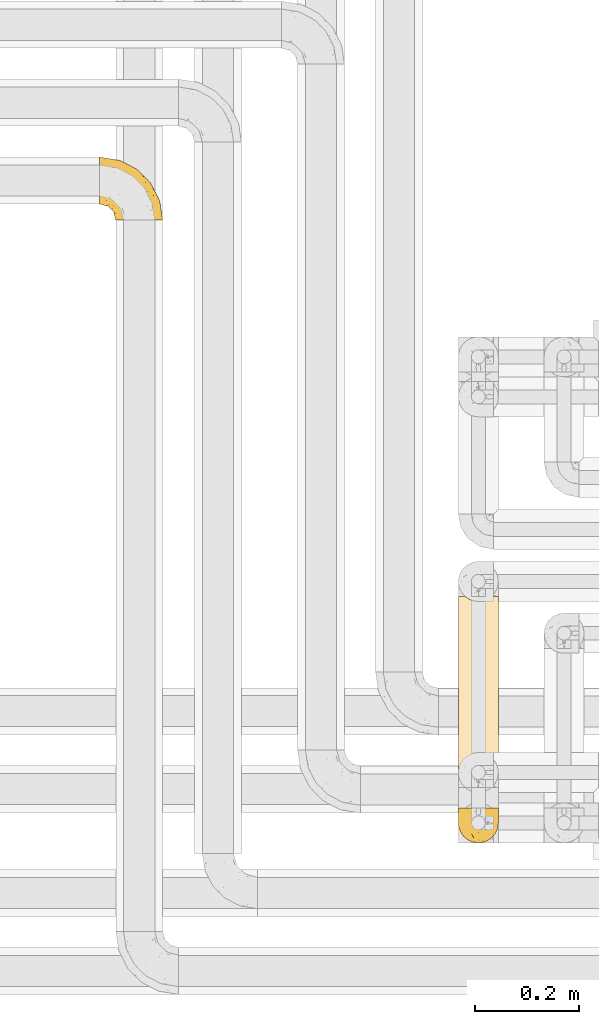
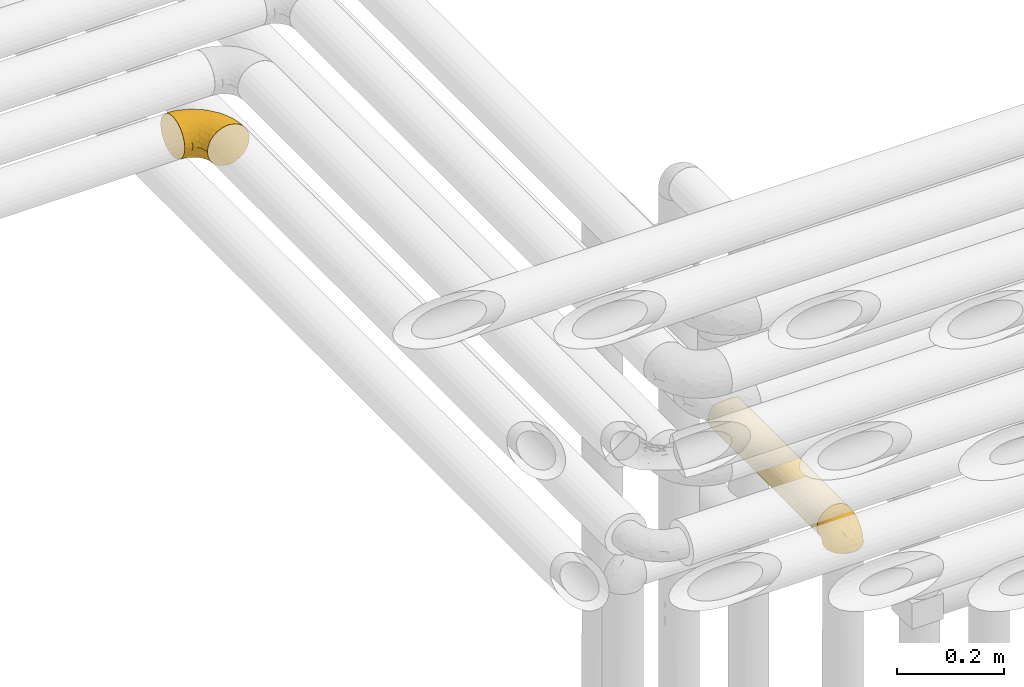
# One storey, part 285 of 827: 3 coverings.
"""IFC2X3 building model written with IfcOpenShell, lengths in millimetres."""

from ifc_helpers import new_model, entity, si_unit, converted_unit, derived_unit, direction, frame, origin, place, context, subcontext, project, spatial, faceted_brep, element, save


model = new_model("IFC2X3")

# Units and contexts
model_context = context("Model", 3, precision=0.01, world=origin(), true_north=direction((6.12303176911189e-17, 1.0)))
body_context = subcontext(model_context, "Body", "Model", "MODEL_VIEW")
ifc_project = project(units=[si_unit("LENGTHUNIT", "METRE", prefix="MILLI"), si_unit("AREAUNIT", "SQUARE_METRE"), si_unit("VOLUMEUNIT", "CUBIC_METRE"), converted_unit("PLANEANGLEUNIT", "DEGREE", entity("IfcRatioMeasure", 0.0174532925199433), si_unit("PLANEANGLEUNIT", "RADIAN"), dimensions=[0, 0, 0, 0, 0, 0, 0]), si_unit("MASSUNIT", "GRAM", prefix="KILO"), derived_unit("MASSDENSITYUNIT", [(si_unit("MASSUNIT", "GRAM", prefix="KILO"), 1), (si_unit("LENGTHUNIT", "METRE"), -3)]), derived_unit("MOMENTOFINERTIAUNIT", [(si_unit("LENGTHUNIT", "METRE"), 4)]), si_unit("TIMEUNIT", "SECOND"), si_unit("FREQUENCYUNIT", "HERTZ"), si_unit("THERMODYNAMICTEMPERATUREUNIT", "DEGREE_CELSIUS"), derived_unit("THERMALTRANSMITTANCEUNIT", [(si_unit("MASSUNIT", "GRAM", prefix="KILO"), 1), (si_unit("THERMODYNAMICTEMPERATUREUNIT", "KELVIN"), -1), (si_unit("TIMEUNIT", "SECOND"), -3)]), derived_unit("VOLUMETRICFLOWRATEUNIT", [(si_unit("LENGTHUNIT", "METRE"), 3), (si_unit("TIMEUNIT", "SECOND"), -1)]), derived_unit("MASSFLOWRATEUNIT", [(si_unit("MASSUNIT", "GRAM", prefix="KILO"), 1), (si_unit("TIMEUNIT", "SECOND"), -1)]), derived_unit("ROTATIONALFREQUENCYUNIT", [(si_unit("TIMEUNIT", "SECOND"), -1)]), si_unit("ELECTRICCURRENTUNIT", "AMPERE"), si_unit("ELECTRICVOLTAGEUNIT", "VOLT"), si_unit("POWERUNIT", "WATT"), si_unit("FORCEUNIT", "NEWTON", prefix="KILO"), si_unit("ILLUMINANCEUNIT", "LUX"), si_unit("LUMINOUSFLUXUNIT", "LUMEN"), si_unit("LUMINOUSINTENSITYUNIT", "CANDELA"), derived_unit("USERDEFINED", [(si_unit("MASSUNIT", "GRAM", prefix="KILO"), -1), (si_unit("LENGTHUNIT", "METRE"), -2), (si_unit("TIMEUNIT", "SECOND"), 3), (si_unit("LUMINOUSFLUXUNIT", "LUMEN"), 1)]), derived_unit("LINEARVELOCITYUNIT", [(si_unit("LENGTHUNIT", "METRE"), 1), (si_unit("TIMEUNIT", "SECOND"), -1)]), si_unit("PRESSUREUNIT", "PASCAL"), derived_unit("USERDEFINED", [(si_unit("LENGTHUNIT", "METRE"), -2), (si_unit("MASSUNIT", "GRAM", prefix="KILO"), 1), (si_unit("TIMEUNIT", "SECOND"), -2)]), derived_unit("LINEARFORCEUNIT", [(si_unit("MASSUNIT", "GRAM", prefix="KILO"), 1), (si_unit("LENGTHUNIT", "METRE"), 1), (si_unit("TIMEUNIT", "SECOND"), -2), (si_unit("LENGTHUNIT", "METRE"), -1)]), derived_unit("PLANARFORCEUNIT", [(si_unit("MASSUNIT", "GRAM", prefix="KILO"), 1), (si_unit("LENGTHUNIT", "METRE"), 1), (si_unit("TIMEUNIT", "SECOND"), -2), (si_unit("LENGTHUNIT", "METRE"), -2)])], contexts=[model_context])

# Site, building, storey
site_placement = place(None, origin())
site = spatial("IfcSite", under=ifc_project, at=site_placement, CompositionType="ELEMENT")
building_placement = place(site_placement, origin())
building = spatial("IfcBuilding", under=site, at=building_placement, CompositionType="ELEMENT")
storey_placement = place(building_placement, frame((0.0, 0.0, 28200.0)))
storey = spatial("IfcBuildingStorey", under=building, at=storey_placement, Name="08", CompositionType="ELEMENT", Elevation=28200.0)

# Coverings
covering_1_placement = place(storey_placement, frame((34097.44, 16083.61, 3153.25)))
element("IfcCovering", 1, at=covering_1_placement, inside=storey, Name=":ADSK_", ObjectType=":ADSK_", PredefinedType="INSULATION", context=body_context, shape_type="Brep", body=[
    faceted_brep([(1.6, 87.65, 90.76), (1.6, 97.19, 87.42), (1.6, 105.75, 82.04), (1.6, 112.9, 74.89), (1.6, 118.28, 66.33), (1.6, 121.61, 56.79), (1.6, 122.75, 46.75), (1.6, 121.61, 36.69), (1.6, 118.27, 27.15), (1.6, 112.89, 18.59), (1.6, 105.74, 11.44), (1.6, 97.18, 6.06), (1.6, 87.64, 2.73), (1.6, 77.6, 1.6), (1.6, 67.54, 2.73), (1.6, 58.0, 6.07), (1.6, 49.44, 11.45), (1.6, 42.29, 18.6), (1.6, 36.91, 27.16), (1.6, 33.58, 36.7), (1.6, 32.45, 46.75), (1.6, 33.58, 56.8), (1.6, 36.92, 66.34), (1.6, 42.3, 74.9), (1.6, 49.45, 82.05), (1.6, 58.01, 87.43), (1.6, 67.55, 90.76), (1.6, 77.6, 91.9), (33.98, 1.6, 35.06), (38.49, 1.6, 24.17), (45.67, 1.6, 14.82), (55.02, 1.6, 7.64), (65.91, 1.6, 3.13), (77.6, 1.6, 1.6), (89.28, 1.6, 3.13), (100.17, 1.6, 7.64), (109.52, 1.6, 14.82), (116.7, 1.6, 24.17), (121.21, 1.6, 35.06), (122.75, 1.6, 46.75), (121.21, 1.6, 58.43), (116.7, 1.6, 69.32), (109.52, 1.6, 78.67), (100.17, 1.6, 85.85), (89.28, 1.6, 90.36), (77.6, 1.6, 91.9), (65.91, 1.6, 90.36), (55.02, 1.6, 85.85), (45.67, 1.6, 78.67), (38.49, 1.6, 69.32), (33.98, 1.6, 58.43), (32.45, 1.6, 46.75), (72.81, 99.61, 46.75), (77.17, 95.26, 55.2), (86.21, 86.21, 46.75), (116.82, 39.03, 46.75), (118.49, 30.75, 54.53), (119.23, 23.8, 46.75), (105.14, 60.8, 59.63), (85.37, 85.37, 62.07), (89.33, 73.64, 71.86), (116.14, 31.01, 62.65), (105.06, 49.14, 71.33), (112.15, 23.88, 72.93), (22.95, 82.74, 91.2), (89.91, 43.48, 86.31), (103.39, 29.47, 80.89), (93.6, 56.38, 79.49), (51.41, 72.18, 90.68), (67.71, 72.24, 86.84), (43.53, 87.6, 87.38), (30.91, 107.24, 76.87), (23.58, 101.1, 83.73), (50.07, 95.16, 81.03), (30.68, 71.81, 91.9), (43.01, 63.57, 91.9), (55.34, 55.34, 91.9), (83.48, 23.66, 91.03), (94.96, 20.55, 87.58), (57.29, 107.97, 56.52), (39.03, 116.82, 46.75), (30.66, 117.03, 60.4), (71.81, 30.68, 91.9), (73.63, 21.51, 91.9), (75.46, 12.33, 91.9), (51.57, 106.17, 67.87), (73.13, 52.37, 90.35), (23.16, 114.51, 69.57), (23.8, 119.23, 46.75), (75.6, 78.37, 79.91), (12.33, 75.46, 91.9), (21.51, 73.63, 91.9), (50.46, 101.51, 74.99), (99.61, 72.81, 46.75), (63.57, 43.01, 91.9), (21.26, 92.6, 88.53), (69.54, 91.86, 72.65), (108.21, 55.92, 46.75), (68.42, 99.01, 62.97), (55.92, 108.21, 46.75), (19.36, 32.05, 66.2), (15.76, 30.22, 56.6), (26.13, 23.37, 59.89), (62.78, 28.43, 90.95), (63.65, 16.44, 90.22), (24.34, 37.1, 76.64), (28.46, 28.88, 71.58), (33.53, 33.93, 79.99), (39.46, 50.17, 89.54), (51.05, 40.57, 89.97), (10.94, 47.62, 81.32), (14.55, 39.9, 74.56), (22.21, 47.92, 84.15), (57.05, 34.27, 90.37), (54.0, 24.65, 87.82), (29.19, 62.6, 90.98), (18.85, 66.18, 90.96), (52.84, 11.74, 85.14), (31.47, 13.89, 58.11), (28.31, 17.02, 46.75), (43.0, 15.86, 78.39), (16.9, 57.71, 88.22), (35.98, 9.11, 66.06), (33.91, 18.55, 68.6), (9.97, 34.74, 63.78), (25.93, 54.95, 88.42), (35.61, 57.35, 90.61), (47.45, 22.03, 83.8), (38.26, 24.8, 77.98), (11.7, 69.07, 91.22), (30.13, 42.31, 83.46), (12.12, 29.63, 46.75), (17.02, 28.31, 46.75), (44.39, 30.23, 84.66), (39.83, 40.13, 86.33), (22.67, 22.67, 46.75), (29.63, 12.12, 46.75), (43.0, 15.86, 15.1), (47.45, 22.03, 9.69), (38.26, 24.8, 15.52), (44.38, 30.23, 8.83), (31.47, 13.88, 35.39), (10.93, 47.61, 12.18), (21.51, 73.63, 1.6), (18.84, 66.17, 2.53), (11.7, 69.07, 2.27), (15.76, 30.22, 36.9), (19.36, 32.04, 27.31), (26.14, 23.36, 33.62), (25.94, 54.93, 5.07), (22.21, 47.91, 9.36), (16.9, 57.69, 5.27), (35.98, 9.1, 27.43), (73.63, 21.51, 1.6), (75.46, 12.33, 1.6), (30.12, 42.29, 10.05), (24.33, 37.09, 16.87), (52.84, 11.74, 8.35), (63.65, 16.44, 3.27), (71.81, 30.68, 1.6), (28.45, 28.86, 21.94), (9.97, 34.74, 29.72), (43.01, 63.57, 1.6), (55.34, 55.34, 1.6), (39.46, 50.17, 3.96), (12.33, 75.46, 1.6), (14.54, 39.89, 18.95), (62.78, 28.43, 2.54), (57.05, 34.27, 3.12), (63.57, 43.01, 1.6), (29.2, 62.59, 2.51), (51.05, 40.57, 3.52), (39.81, 40.13, 7.17), (30.68, 71.81, 1.6), (33.52, 33.92, 13.52), (35.61, 57.34, 2.88), (54.0, 24.65, 5.67), (33.91, 18.54, 24.89), (103.39, 29.47, 12.6), (89.91, 43.48, 7.18), (93.6, 56.4, 14.0), (105.05, 49.17, 22.16), (89.27, 73.69, 21.61), (73.13, 52.37, 3.14), (67.67, 72.26, 6.65), (69.49, 91.88, 20.82), (85.36, 85.36, 31.41), (94.96, 20.55, 5.91), (83.48, 23.66, 2.46), (105.14, 60.8, 33.87), (116.13, 31.02, 30.84), (118.49, 30.75, 38.96), (112.15, 23.9, 20.56), (51.41, 72.17, 2.81), (43.51, 87.59, 6.1), (22.95, 82.74, 2.29), (30.66, 117.03, 33.08), (30.91, 107.23, 16.61), (57.3, 107.97, 36.96), (23.58, 101.08, 9.75), (51.56, 106.17, 25.61), (68.41, 99.01, 30.5), (23.16, 114.5, 23.91), (50.07, 95.15, 12.45), (50.45, 101.5, 18.49), (21.25, 92.59, 4.96), (75.56, 78.38, 13.56), (77.16, 95.27, 38.28)], [[[0, 1, 2, 3, 4, 5, 6, 7, 8, 9, 10, 11, 12, 13, 14, 15, 16, 17, 18, 19, 20, 21, 22, 23, 24, 25, 26, 27]], [[28, 29, 30, 31, 32, 33, 34, 35, 36, 37, 38, 39, 40, 41, 42, 43, 44, 45, 46, 47, 48, 49, 50, 51]], [[52, 53, 54]], [[55, 56, 57]], [[58, 59, 60]], [[61, 62, 63]], [[27, 64, 0]], [[65, 66, 67]], [[41, 40, 61]], [[68, 69, 70]], [[66, 43, 42]], [[63, 42, 41]], [[71, 72, 73]], [[72, 2, 1]], [[68, 74, 75, 76]], [[45, 44, 77]], [[43, 78, 44]], [[79, 80, 81]], [[77, 82, 83, 84, 45]], [[79, 81, 85]], [[71, 2, 72]], [[65, 86, 77]], [[4, 81, 5]], [[66, 65, 78]], [[4, 3, 87]], [[81, 88, 5]], [[63, 66, 42]], [[68, 70, 64]], [[67, 60, 89]], [[71, 3, 2]], [[64, 27, 90, 91, 74]], [[92, 71, 73]], [[40, 57, 56]], [[59, 93, 54]], [[86, 76, 94, 82]], [[1, 0, 95]], [[58, 62, 61]], [[60, 96, 89]], [[85, 81, 87]], [[56, 97, 58]], [[65, 67, 69]], [[87, 81, 4]], [[67, 89, 69]], [[61, 63, 41]], [[95, 72, 1]], [[73, 72, 70]], [[69, 73, 70]], [[73, 89, 96]], [[3, 71, 87]], [[85, 87, 71]], [[58, 61, 56]], [[59, 58, 93]], [[76, 86, 68]], [[69, 89, 73]], [[68, 86, 69]], [[65, 69, 86]], [[68, 64, 74]], [[95, 64, 70]], [[98, 79, 85]], [[79, 52, 99, 80]], [[66, 62, 67]], [[62, 58, 60]], [[62, 60, 67]], [[59, 98, 96]], [[59, 96, 60]], [[96, 85, 92]], [[88, 81, 80]], [[88, 6, 5]], [[66, 63, 62]], [[64, 95, 0]], [[72, 95, 70]], [[77, 44, 78]], [[86, 82, 77]], [[40, 39, 57]], [[96, 98, 85]], [[40, 56, 61]], [[66, 78, 43]], [[77, 78, 65]], [[79, 98, 53]], [[96, 92, 73]], [[85, 71, 92]], [[97, 56, 55]], [[97, 93, 58]], [[53, 98, 59]], [[54, 53, 59]], [[79, 53, 52]], [[100, 101, 102]], [[46, 45, 84, 83]], [[103, 104, 82]], [[82, 104, 83]], [[105, 106, 107]], [[108, 109, 76]], [[110, 111, 112]], [[103, 113, 114]], [[115, 74, 116]], [[48, 47, 117]], [[118, 102, 119]], [[49, 48, 120]], [[74, 91, 116]], [[116, 121, 115]], [[49, 122, 50]], [[123, 106, 102]], [[124, 111, 22]], [[125, 126, 115]], [[23, 22, 111]], [[24, 110, 121]], [[120, 127, 128]], [[90, 26, 129]], [[27, 26, 90]], [[121, 125, 115]], [[24, 121, 25]], [[130, 105, 107]], [[129, 25, 116]], [[21, 20, 131]], [[120, 123, 122]], [[112, 105, 130]], [[50, 118, 51]], [[21, 124, 22]], [[101, 131, 132]], [[117, 120, 48]], [[24, 23, 110]], [[127, 114, 133]], [[75, 108, 76]], [[107, 134, 130]], [[133, 114, 113]], [[129, 116, 91]], [[25, 121, 116]], [[121, 112, 125]], [[75, 74, 115]], [[101, 135, 102]], [[131, 101, 21]], [[101, 100, 124]], [[128, 127, 133]], [[119, 136, 51, 118]], [[104, 47, 46]], [[83, 104, 46]], [[117, 104, 114]], [[101, 124, 21]], [[111, 124, 100]], [[102, 118, 123]], [[133, 134, 107]], [[111, 110, 23]], [[114, 104, 103]], [[94, 76, 109]], [[121, 110, 112]], [[122, 118, 50]], [[134, 109, 108]], [[133, 107, 128]], [[112, 108, 125]], [[126, 125, 108]], [[108, 75, 126]], [[75, 115, 126]], [[109, 134, 133]], [[130, 108, 112]], [[108, 130, 134]], [[105, 112, 111]], [[111, 100, 105]], [[106, 105, 100]], [[102, 106, 100]], [[128, 106, 123]], [[90, 129, 91]], [[25, 129, 26]], [[104, 117, 47]], [[117, 114, 127]], [[82, 94, 103]], [[113, 94, 109]], [[94, 113, 103]], [[133, 113, 109]], [[106, 128, 107]], [[123, 120, 128]], [[120, 122, 49]], [[118, 122, 123]], [[135, 101, 132]], [[135, 119, 102]], [[117, 127, 120]], [[30, 29, 137]], [[138, 139, 140]], [[51, 136, 119, 141]], [[142, 17, 16]], [[143, 144, 145]], [[146, 147, 148]], [[149, 150, 151]], [[152, 29, 28]], [[33, 32, 153, 154]], [[150, 155, 156]], [[157, 31, 30]], [[153, 158, 159]], [[29, 152, 137]], [[148, 141, 119]], [[156, 160, 147]], [[148, 135, 146]], [[137, 138, 157]], [[19, 161, 146]], [[162, 163, 164]], [[14, 13, 165]], [[153, 32, 158]], [[147, 161, 166]], [[18, 17, 166]], [[167, 168, 169]], [[166, 150, 156]], [[151, 150, 142]], [[151, 170, 149]], [[151, 16, 15]], [[171, 140, 172]], [[165, 143, 145]], [[173, 170, 144]], [[142, 166, 17]], [[19, 131, 20]], [[144, 170, 151]], [[18, 161, 19]], [[173, 144, 143]], [[140, 139, 174]], [[171, 164, 163]], [[164, 172, 155]], [[151, 15, 144]], [[145, 15, 14]], [[173, 162, 170]], [[149, 175, 164]], [[19, 146, 131]], [[132, 131, 146]], [[160, 148, 147]], [[159, 158, 167]], [[135, 132, 146]], [[158, 32, 31]], [[157, 158, 31]], [[167, 158, 176]], [[166, 161, 18]], [[146, 161, 147]], [[148, 177, 141]], [[171, 168, 140]], [[171, 163, 169]], [[151, 142, 16]], [[166, 142, 150]], [[152, 141, 177]], [[51, 141, 28]], [[138, 140, 176]], [[172, 140, 174]], [[175, 149, 170]], [[164, 150, 149]], [[170, 162, 175]], [[162, 164, 175]], [[155, 172, 174]], [[171, 172, 164]], [[155, 174, 156]], [[164, 155, 150]], [[160, 156, 174]], [[147, 166, 156]], [[139, 160, 174]], [[148, 160, 177]], [[15, 145, 144]], [[165, 145, 14]], [[137, 157, 30]], [[158, 157, 176]], [[168, 167, 176]], [[169, 159, 167]], [[140, 168, 176]], [[169, 168, 171]], [[137, 177, 139]], [[160, 139, 177]], [[141, 152, 28]], [[137, 152, 177]], [[148, 119, 135]], [[157, 138, 176]], [[139, 138, 137]], [[178, 179, 180]], [[181, 180, 182]], [[179, 183, 184]], [[185, 186, 182]], [[187, 188, 179]], [[188, 33, 154, 153, 159]], [[181, 189, 190]], [[35, 34, 187]], [[191, 38, 190]], [[192, 178, 181]], [[179, 184, 180]], [[192, 190, 37]], [[37, 190, 38]], [[36, 35, 178]], [[54, 93, 186]], [[35, 187, 178]], [[193, 194, 184]], [[195, 173, 143, 165, 13]], [[195, 193, 173]], [[193, 163, 162, 173]], [[13, 12, 195]], [[8, 7, 196]], [[9, 197, 10]], [[198, 80, 99, 52]], [[196, 7, 88]], [[197, 199, 10]], [[182, 189, 181]], [[200, 198, 201]], [[200, 196, 198]], [[9, 8, 202]], [[194, 199, 203]], [[192, 37, 36]], [[80, 196, 88]], [[183, 159, 169, 163]], [[188, 34, 33]], [[202, 200, 197]], [[185, 203, 204]], [[202, 8, 196]], [[10, 199, 11]], [[12, 11, 205]], [[38, 191, 57]], [[189, 97, 191]], [[203, 199, 197]], [[205, 199, 194]], [[204, 203, 197]], [[184, 203, 206]], [[200, 202, 196]], [[197, 9, 202]], [[207, 54, 186]], [[97, 55, 191]], [[194, 203, 184]], [[183, 163, 193]], [[184, 206, 180]], [[183, 193, 184]], [[205, 195, 12]], [[193, 195, 194]], [[80, 198, 196]], [[207, 186, 201]], [[182, 180, 206]], [[181, 178, 180]], [[185, 182, 206]], [[182, 186, 189]], [[203, 185, 206]], [[185, 200, 201]], [[7, 6, 88]], [[178, 192, 36]], [[190, 192, 181]], [[199, 205, 11]], [[195, 205, 194]], [[159, 183, 188]], [[179, 188, 183]], [[57, 191, 55]], [[57, 39, 38]], [[189, 191, 190]], [[188, 187, 34]], [[178, 187, 179]], [[186, 93, 189]], [[197, 200, 204]], [[185, 204, 200]], [[189, 93, 97]], [[207, 198, 52]], [[185, 201, 186]], [[198, 207, 201]], [[54, 207, 52]]]),
])
covering_2_placement = place(storey_placement, frame((34787.85, 14952.42, 2760.0)))
element("IfcCovering", 2, at=covering_2_placement, inside=storey, Name=":ADSK_", ObjectType=":ADSK_", PredefinedType="INSULATION", context=body_context, shape_type="Brep", body=[
    faceted_brep([(5.09, 1.6, 23.98), (9.31, 1.6, 16.91), (14.94, 1.6, 10.9), (65.05, 1.6, 10.9), (70.68, 1.6, 16.91), (74.9, 1.6, 23.98), (77.51, 1.6, 31.79), (78.4, 1.6, 40.0), (77.09, 1.6, 49.93), (73.25, 1.6, 59.2), (67.15, 1.6, 67.15), (59.2, 1.6, 73.25), (49.93, 1.6, 77.09), (40.0, 1.6, 78.4), (30.06, 1.6, 77.09), (20.8, 1.6, 73.25), (12.84, 1.6, 67.15), (6.74, 1.6, 59.2), (2.9, 1.6, 49.93), (1.6, 1.6, 40.0), (2.48, 1.6, 31.79), (40.0, 408.08, 1.6), (30.06, 408.08, 2.9), (20.8, 408.08, 6.74), (12.84, 408.08, 12.84), (6.74, 408.08, 20.8), (2.9, 408.08, 30.06), (1.6, 408.08, 40.0), (2.48, 408.08, 48.2), (5.09, 408.08, 56.01), (9.31, 408.08, 63.08), (14.94, 408.08, 69.1), (65.05, 408.08, 69.1), (70.68, 408.08, 63.08), (74.9, 408.08, 56.01), (77.51, 408.08, 48.2), (78.4, 408.08, 40.0), (77.09, 408.08, 30.06), (73.25, 408.08, 20.8), (67.15, 408.08, 12.84), (59.2, 408.08, 6.74), (49.93, 408.08, 2.9), (1.6, 217.97, 40.0), (40.0, 227.27, 1.6), (29.82, 196.67, 2.97), (6.61, 193.65, 21.03), (3.58, 193.04, 27.82), (10.95, 205.8, 14.88), (33.21, 10.29, 2.2), (26.63, 8.5, 4.0), (1.6, 191.71, 40.0), (17.5, 209.65, 8.87), (23.38, 180.88, 5.38), (40.0, 10.9, 1.6), (20.48, 5.57, 6.92), (50.17, 196.67, 2.97), (56.57, 227.88, 5.35), (62.49, 209.65, 8.87), (69.04, 205.8, 14.88), (46.78, 10.29, 2.2), (53.36, 8.5, 4.0), (59.51, 5.57, 6.92), (73.38, 193.65, 21.03), (76.41, 193.04, 27.82), (78.4, 217.97, 40.0), (78.4, 191.71, 40.0), (76.41, 216.64, 52.17), (59.51, 404.11, 73.07), (56.57, 181.8, 74.64), (62.49, 200.03, 71.12), (50.17, 213.01, 77.02), (73.38, 216.03, 58.96), (40.0, 182.41, 78.4), (46.78, 399.39, 77.79), (69.04, 203.88, 65.11), (53.36, 401.18, 76.0), (40.0, 398.78, 78.4), (20.48, 404.11, 73.07), (23.38, 228.8, 74.61), (26.63, 401.18, 76.0), (17.5, 200.03, 71.12), (29.82, 213.01, 77.02), (33.21, 399.39, 77.79), (10.95, 203.88, 65.11), (6.61, 216.03, 58.96), (3.58, 216.64, 52.17)], [[[0, 1, 2, 3, 4, 5, 6, 7, 8, 9, 10, 11, 12, 13, 14, 15, 16, 17, 18, 19, 20]], [[21, 22, 23, 24, 25, 26, 27, 28, 29, 30, 31, 32, 33, 34, 35, 36, 37, 38, 39, 40, 41]], [[42, 27, 26]], [[43, 44, 22]], [[45, 46, 25]], [[45, 47, 1]], [[44, 48, 49]], [[20, 19, 50, 42]], [[25, 46, 26]], [[0, 20, 46]], [[0, 46, 45]], [[42, 26, 46]], [[47, 51, 2]], [[42, 46, 20]], [[22, 44, 52]], [[23, 52, 51]], [[25, 47, 45]], [[53, 48, 43]], [[51, 47, 24]], [[43, 48, 44]], [[24, 23, 51]], [[2, 51, 54]], [[47, 2, 1]], [[54, 52, 49]], [[52, 54, 51]], [[21, 43, 22]], [[1, 0, 45]], [[52, 23, 22]], [[49, 52, 44]], [[47, 25, 24]], [[43, 41, 55]], [[41, 43, 21]], [[41, 56, 55]], [[40, 57, 56]], [[57, 39, 58]], [[59, 55, 60]], [[59, 53, 43]], [[56, 60, 55]], [[56, 61, 60]], [[40, 39, 57]], [[57, 3, 61]], [[43, 55, 59]], [[38, 62, 58]], [[38, 58, 39]], [[38, 37, 63]], [[58, 62, 4]], [[58, 4, 3]], [[6, 64, 65, 7]], [[63, 5, 62]], [[38, 63, 62]], [[64, 63, 37]], [[5, 63, 6]], [[64, 6, 63]], [[36, 64, 37]], [[5, 4, 62]], [[3, 57, 58]], [[61, 56, 57]], [[56, 41, 40]], [[65, 35, 66]], [[66, 35, 34]], [[67, 68, 69]], [[12, 68, 70]], [[66, 71, 9]], [[72, 70, 73]], [[35, 65, 64, 36]], [[66, 34, 71]], [[66, 9, 8]], [[9, 71, 74]], [[68, 12, 11]], [[69, 74, 32]], [[68, 75, 70]], [[69, 10, 74]], [[73, 70, 75]], [[11, 10, 69]], [[73, 76, 72]], [[75, 68, 67]], [[65, 66, 8]], [[68, 11, 69]], [[74, 71, 33]], [[72, 13, 12]], [[12, 70, 72]], [[34, 33, 71]], [[74, 33, 32]], [[67, 69, 32]], [[9, 74, 10]], [[7, 65, 8]], [[77, 78, 79]], [[16, 15, 80]], [[31, 80, 77]], [[81, 82, 79]], [[83, 31, 30]], [[80, 78, 77]], [[72, 82, 81]], [[72, 81, 14]], [[82, 72, 76]], [[14, 81, 78]], [[13, 72, 14]], [[15, 14, 78]], [[84, 29, 85]], [[15, 78, 80]], [[85, 29, 28]], [[17, 83, 84]], [[80, 83, 16]], [[50, 19, 18]], [[50, 85, 28]], [[30, 84, 83]], [[83, 17, 16]], [[85, 17, 84]], [[85, 50, 18]], [[17, 85, 18]], [[30, 29, 84]], [[31, 83, 80]], [[79, 78, 81]], [[28, 27, 42, 50]], [[54, 49, 48, 53, 59, 60, 61, 3, 2]], [[77, 79, 82, 76, 73, 75, 67, 32, 31]]]),
])
covering_3_placement = place(storey_placement, frame((34787.8, 14884.87, 2769.3)))
element("IfcCovering", 3, at=covering_3_placement, inside=storey, Name=":ADSK_", ObjectType=":ADSK_", PredefinedType="INSULATION", context=body_context, shape_type="Brep", body=[
    faceted_brep([(5.41, 69.15, 47.38), (9.99, 69.15, 54.67), (16.08, 69.15, 60.76), (23.37, 69.15, 65.34), (31.49, 69.15, 68.18), (40.05, 69.15, 69.15), (48.61, 69.15, 68.18), (56.73, 69.15, 65.33), (64.02, 69.15, 60.75), (70.11, 69.15, 54.66), (74.69, 69.15, 47.37), (77.53, 69.15, 39.25), (78.5, 69.15, 30.7), (77.63, 69.15, 22.59), (75.08, 69.15, 14.86), (70.97, 69.15, 7.84), (65.47, 69.15, 1.85), (63.27, 69.15, 1.85), (61.53, 69.15, 1.85), (59.57, 69.15, 1.85), (57.6, 69.15, 1.85), (55.63, 69.15, 1.85), (53.67, 69.15, 1.85), (51.7, 69.15, 1.85), (49.73, 69.15, 1.85), (47.54, 69.15, 1.85), (45.34, 69.15, 1.85), (43.15, 69.15, 1.85), (40.96, 69.15, 1.85), (38.76, 69.15, 1.85), (36.57, 69.15, 1.85), (34.37, 69.15, 1.85), (32.18, 69.15, 1.85), (29.98, 69.15, 1.85), (27.79, 69.15, 1.85), (25.6, 69.15, 1.85), (23.4, 69.15, 1.85), (21.21, 69.15, 1.85), (19.01, 69.15, 1.85), (16.82, 69.15, 1.85), (14.62, 69.15, 1.85), (9.12, 69.15, 7.85), (5.0, 69.15, 14.88), (2.46, 69.15, 22.61), (1.6, 69.15, 30.7), (2.56, 69.15, 39.26), (65.47, 68.89, 1.6), (70.97, 62.89, 1.6), (75.09, 55.87, 1.6), (77.63, 48.14, 1.6), (78.5, 40.05, 1.6), (77.19, 30.09, 1.6), (73.34, 20.82, 1.6), (67.23, 12.86, 1.6), (59.27, 6.75, 1.6), (50.0, 2.91, 1.6), (40.05, 1.6, 1.6), (30.09, 2.91, 1.6), (20.82, 6.75, 1.6), (12.86, 12.86, 1.6), (6.75, 20.82, 1.6), (2.91, 30.09, 1.6), (1.6, 40.05, 1.6), (2.46, 48.14, 1.6), (5.0, 55.87, 1.6), (9.12, 62.89, 1.6), (14.62, 68.89, 1.6), (16.82, 68.89, 1.6), (17.8, 68.89, 1.6), (19.39, 68.89, 1.6), (20.98, 68.89, 1.6), (22.57, 68.89, 1.6), (24.16, 68.89, 1.6), (25.75, 68.89, 1.6), (27.33, 68.89, 1.6), (28.92, 68.89, 1.6), (30.51, 68.89, 1.6), (32.1, 68.89, 1.6), (33.69, 68.89, 1.6), (35.28, 68.89, 1.6), (36.87, 68.89, 1.6), (38.46, 68.89, 1.6), (40.05, 68.89, 1.6), (41.63, 68.89, 1.6), (43.22, 68.89, 1.6), (44.81, 68.89, 1.6), (46.4, 68.89, 1.6), (47.99, 68.89, 1.6), (49.58, 68.89, 1.6), (51.17, 68.89, 1.6), (52.76, 68.89, 1.6), (54.72, 68.89, 1.6), (56.69, 68.89, 1.6), (58.88, 68.89, 1.6), (61.08, 68.89, 1.6), (63.27, 68.89, 1.6), (37.77, 68.97, 1.78), (36.07, 68.96, 1.77), (32.96, 68.97, 1.78), (31.36, 68.97, 1.77), (56.52, 68.98, 1.79), (54.96, 68.97, 1.78), (18.75, 68.96, 1.76), (58.07, 68.96, 1.77), (50.37, 68.96, 1.77), (23.36, 68.96, 1.76), (24.95, 68.96, 1.77), (42.43, 68.96, 1.77), (15.97, 69.0, 1.8), (51.96, 68.96, 1.76), (53.47, 68.96, 1.77), (48.63, 68.97, 1.78), (63.93, 68.96, 1.77), (40.93, 68.96, 1.77), (29.72, 68.96, 1.76), (62.4, 68.97, 1.77), (60.92, 68.97, 1.78), (17.31, 68.97, 1.77), (21.74, 68.96, 1.77), (34.56, 68.96, 1.77), (20.18, 68.97, 1.78), (14.62, 68.97, 1.77), (14.62, 69.02, 1.8), (14.62, 69.08, 1.82), (65.47, 68.97, 1.77), (65.47, 68.94, 1.72), (65.47, 68.92, 1.66), (59.5, 68.96, 1.76), (47.1, 68.96, 1.77), (45.61, 68.95, 1.76), (28.18, 68.96, 1.77), (14.62, 68.92, 1.66), (14.62, 68.94, 1.72), (26.61, 68.98, 1.78), (65.47, 69.08, 1.82), (65.47, 69.02, 1.8), (39.32, 68.96, 1.77), (44.12, 68.97, 1.78), (72.26, 61.33, 3.72), (76.57, 53.1, 7.41), (71.77, 63.33, 6.13), (77.9, 55.53, 19.34), (76.56, 63.33, 17.64), (78.5, 54.6, 26.8), (78.5, 41.99, 8.87), (75.52, 57.07, 9.2), (76.13, 57.95, 12.79), (77.81, 51.56, 14.62), (78.5, 41.58, 7.34), (72.4, 61.7, 5.33), (71.77, 65.0, 7.7), (72.25, 67.02, 9.41), (78.5, 61.87, 28.75), (78.5, 49.27, 21.47), (78.5, 43.94, 16.15), (75.75, 61.21, 14.14), (78.5, 63.4, 29.16), (50.46, 33.11, 57.02), (52.75, 52.82, 64.92), (40.05, 43.3, 64.0), (77.7, 33.73, 11.92), (77.66, 36.52, 19.16), (71.02, 24.87, 28.65), (63.45, 14.17, 24.62), (70.55, 18.43, 15.19), (75.57, 28.67, 18.36), (75.57, 26.0, 9.2), (72.61, 49.25, 46.98), (72.61, 59.72, 50.24), (67.24, 55.1, 56.1), (77.74, 44.72, 28.97), (57.43, 34.15, 54.46), (47.19, 5.25, 21.34), (54.76, 6.75, 18.4), (40.05, 55.54, 66.44), (63.45, 10.47, 12.07), (60.1, 25.49, 45.49), (63.72, 35.53, 50.57), (76.83, 48.22, 36.04), (76.34, 58.71, 42.07), (60.51, 57.42, 62.12), (72.59, 34.84, 37.37), (76.05, 36.87, 29.39), (66.15, 45.01, 53.59), (60.51, 44.4, 58.06), (51.88, 23.96, 49.27), (55.34, 11.2, 29.63), (48.67, 10.56, 33.21), (53.89, 16.81, 40.1), (46.73, 17.38, 44.08), (40.05, 21.38, 49.36), (40.05, 32.34, 56.68), (40.05, 4.3, 15.2), (63.95, 20.65, 35.57), (67.24, 29.66, 41.7), (69.62, 39.6, 46.4), (73.6, 42.55, 41.41), (40.05, 6.74, 27.45), (40.05, 14.06, 38.4), (4.52, 26.84, 12.99), (32.72, 5.28, 21.33), (27.18, 18.52, 42.89), (29.63, 33.13, 57.04), (12.86, 55.1, 56.11), (19.59, 57.43, 62.13), (9.54, 20.72, 21.89), (16.64, 11.46, 16.62), (17.48, 17.69, 32.9), (7.49, 49.26, 46.99), (7.49, 59.73, 50.25), (3.75, 58.71, 42.08), (20.75, 29.72, 49.91), (2.33, 35.35, 15.6), (1.6, 43.94, 16.15), (1.6, 41.99, 8.87), (1.6, 63.4, 29.16), (26.94, 4.93, 13.16), (9.54, 17.46, 10.83), (31.21, 10.94, 33.8), (25.33, 8.92, 25.02), (27.35, 52.83, 64.92), (8.17, 29.34, 32.83), (4.3, 30.26, 20.56), (19.59, 44.4, 58.07), (2.23, 39.06, 21.46), (2.45, 43.06, 28.1), (1.6, 54.6, 26.8), (1.6, 49.27, 21.47), (12.86, 42.69, 51.29), (3.27, 48.2, 36.04), (1.6, 61.87, 28.75), (2.29, 33.44, 8.45), (12.86, 29.67, 41.73), (6.89, 38.5, 39.27), (12.43, 23.35, 33.56), (4.1, 34.97, 27.29), (3.53, 53.1, 7.41), (6.88, 59.68, 3.51), (8.16, 62.19, 4.68), (9.02, 64.11, 5.52), (5.0, 57.97, 8.75), (3.96, 57.95, 12.79), (3.52, 63.33, 17.65), (2.4, 51.77, 13.9), (7.83, 67.02, 9.42), (8.32, 64.98, 7.68), (2.19, 55.53, 19.33), (4.34, 61.22, 14.13)], [[[0, 1, 2, 3, 4, 5, 6, 7, 8, 9, 10, 11, 12, 13, 14, 15, 16, 17, 18, 19, 20, 21, 22, 23, 24, 25, 26, 27, 28, 29, 30, 31, 32, 33, 34, 35, 36, 37, 38, 39, 40, 41, 42, 43, 44, 45]], [[46, 47, 48, 49, 50, 51, 52, 53, 54, 55, 56, 57, 58, 59, 60, 61, 62, 63, 64, 65, 66, 67, 68, 69, 70, 71, 72, 73, 74, 75, 76, 77, 78, 79, 80, 81, 82, 83, 84, 85, 86, 87, 88, 89, 90, 91, 92, 93, 94, 95]], [[96, 97, 30]], [[98, 77, 99]], [[100, 101, 21]], [[69, 68, 102]], [[20, 19, 103]], [[24, 23, 104]], [[20, 103, 100]], [[72, 105, 106]], [[84, 83, 107]], [[89, 88, 104]], [[108, 67, 66]], [[109, 110, 90]], [[111, 25, 24]], [[112, 17, 16]], [[82, 113, 83]], [[109, 23, 22]], [[114, 76, 75]], [[105, 36, 106]], [[104, 111, 24]], [[18, 115, 116]], [[97, 96, 80]], [[67, 108, 117]], [[105, 71, 118]], [[31, 97, 119]], [[102, 120, 69]], [[108, 121, 122, 123, 40]], [[112, 95, 115]], [[17, 115, 18]], [[94, 116, 115]], [[117, 68, 67]], [[38, 117, 39]], [[112, 124, 125, 126, 46]], [[17, 112, 115]], [[70, 120, 118]], [[39, 117, 108]], [[120, 38, 37]], [[120, 37, 118]], [[120, 70, 69]], [[116, 94, 127]], [[128, 86, 129]], [[117, 38, 102]], [[74, 130, 75]], [[99, 33, 32]], [[115, 95, 94]], [[39, 108, 40]], [[108, 66, 131, 132]], [[105, 72, 71]], [[118, 37, 36]], [[71, 70, 118]], [[35, 106, 36]], [[36, 105, 118]], [[35, 133, 106]], [[74, 73, 133]], [[106, 133, 73]], [[99, 114, 33]], [[133, 35, 34]], [[73, 72, 106]], [[95, 112, 46]], [[112, 16, 134, 135, 124]], [[130, 114, 75]], [[99, 76, 114]], [[114, 130, 33]], [[34, 33, 130]], [[78, 77, 98]], [[98, 119, 78]], [[130, 133, 34]], [[133, 130, 74]], [[79, 97, 80]], [[98, 99, 32]], [[98, 32, 31]], [[77, 76, 99]], [[97, 79, 119]], [[136, 96, 29]], [[30, 97, 31]], [[136, 29, 28]], [[81, 80, 96]], [[29, 96, 30]], [[31, 119, 98]], [[119, 79, 78]], [[96, 136, 81]], [[82, 81, 136]], [[113, 107, 83]], [[84, 107, 137]], [[107, 27, 137]], [[113, 28, 107]], [[27, 107, 28]], [[85, 84, 137]], [[137, 27, 26]], [[113, 136, 28]], [[136, 113, 82]], [[109, 89, 104]], [[86, 85, 129]], [[89, 109, 90]], [[111, 87, 128]], [[26, 129, 137]], [[88, 111, 104]], [[25, 111, 128]], [[22, 110, 109]], [[23, 109, 104]], [[110, 91, 90]], [[100, 92, 101]], [[110, 22, 101]], [[91, 110, 101]], [[116, 19, 18]], [[111, 88, 87]], [[127, 103, 19]], [[25, 128, 26]], [[86, 128, 87]], [[128, 129, 26]], [[137, 129, 85]], [[120, 102, 38]], [[117, 102, 68]], [[91, 101, 92]], [[21, 101, 22]], [[93, 92, 103]], [[100, 21, 20]], [[100, 103, 92]], [[127, 93, 103]], [[93, 127, 94]], [[116, 127, 19]], [[126, 138, 47]], [[48, 138, 139]], [[140, 125, 124]], [[141, 142, 143]], [[144, 49, 139]], [[145, 140, 146]], [[48, 139, 49]], [[139, 145, 147]], [[49, 144, 148, 50]], [[126, 125, 149]], [[14, 13, 142]], [[150, 146, 140]], [[149, 140, 145]], [[151, 150, 135]], [[151, 14, 142]], [[16, 15, 134]], [[13, 152, 142]], [[124, 150, 140]], [[141, 143, 153]], [[14, 151, 15]], [[15, 151, 134]], [[47, 46, 126]], [[139, 154, 144]], [[138, 48, 47]], [[125, 140, 149]], [[135, 134, 151]], [[146, 155, 141]], [[145, 146, 147]], [[149, 139, 138]], [[147, 153, 154]], [[147, 146, 141]], [[139, 147, 154]], [[139, 149, 145]], [[149, 138, 126]], [[147, 141, 153]], [[146, 150, 155]], [[151, 155, 150]], [[142, 141, 155]], [[13, 12, 156, 152]], [[152, 143, 142]], [[151, 142, 155]], [[150, 124, 135]], [[157, 158, 159]], [[160, 154, 161]], [[162, 163, 164]], [[165, 166, 160]], [[167, 168, 169]], [[153, 170, 161]], [[156, 12, 11]], [[158, 157, 171]], [[172, 55, 173]], [[158, 6, 174]], [[175, 54, 53]], [[52, 166, 164]], [[52, 164, 53]], [[54, 175, 173]], [[166, 52, 51]], [[176, 177, 171]], [[178, 143, 179]], [[156, 11, 179]], [[8, 7, 180]], [[169, 9, 8]], [[179, 143, 152, 156]], [[179, 11, 10]], [[168, 179, 10]], [[181, 162, 182]], [[179, 167, 178]], [[183, 184, 177]], [[183, 169, 184]], [[176, 171, 185]], [[172, 186, 187]], [[158, 7, 6]], [[159, 158, 174]], [[184, 180, 158]], [[54, 173, 55]], [[180, 169, 8]], [[188, 189, 187]], [[9, 168, 10]], [[186, 188, 187]], [[190, 157, 159, 191]], [[55, 172, 192]], [[176, 193, 194]], [[161, 170, 182]], [[162, 164, 165]], [[175, 164, 163]], [[51, 50, 148]], [[167, 195, 196]], [[178, 182, 170]], [[6, 5, 174]], [[158, 180, 7]], [[169, 180, 184]], [[169, 168, 9]], [[179, 168, 167]], [[182, 162, 165]], [[162, 194, 193]], [[161, 165, 160]], [[195, 181, 196]], [[192, 172, 197]], [[192, 56, 55]], [[189, 190, 198]], [[198, 197, 187]], [[172, 187, 197]], [[185, 189, 188]], [[198, 187, 189]], [[186, 172, 173]], [[173, 163, 186]], [[193, 186, 163]], [[176, 185, 188]], [[185, 157, 190]], [[188, 186, 193]], [[177, 176, 194]], [[188, 193, 176]], [[162, 193, 163]], [[195, 177, 194]], [[171, 177, 184]], [[181, 195, 194]], [[183, 167, 169]], [[162, 181, 194]], [[196, 182, 178]], [[158, 171, 184]], [[171, 157, 185]], [[177, 195, 183]], [[167, 183, 195]], [[182, 196, 181]], [[178, 170, 143]], [[178, 167, 196]], [[164, 175, 53]], [[173, 175, 163]], [[160, 51, 148]], [[164, 166, 165]], [[51, 160, 166]], [[160, 148, 144, 154]], [[153, 161, 154]], [[182, 165, 161]], [[190, 189, 185]], [[143, 170, 153]], [[60, 199, 61]], [[197, 200, 192]], [[201, 190, 202]], [[200, 57, 192]], [[203, 204, 2]], [[205, 206, 207]], [[208, 209, 210]], [[211, 207, 201]], [[212, 213, 214]], [[45, 215, 210]], [[216, 206, 58]], [[45, 44, 215]], [[59, 217, 60]], [[60, 217, 199]], [[0, 45, 210]], [[218, 201, 219]], [[202, 159, 220]], [[205, 221, 222]], [[223, 204, 203]], [[1, 203, 2]], [[57, 200, 216]], [[220, 3, 204]], [[220, 174, 4]], [[1, 0, 209]], [[212, 224, 213]], [[225, 226, 227]], [[228, 223, 203]], [[208, 210, 229]], [[210, 226, 229]], [[3, 220, 4]], [[58, 206, 59]], [[209, 203, 1]], [[202, 220, 223]], [[228, 203, 208]], [[202, 211, 201]], [[3, 2, 204]], [[202, 190, 191, 159]], [[210, 215, 230, 226]], [[199, 212, 231]], [[232, 233, 221]], [[233, 208, 229]], [[207, 206, 219]], [[217, 206, 205]], [[227, 224, 225]], [[233, 232, 228]], [[201, 207, 219]], [[234, 232, 221]], [[218, 219, 200]], [[202, 223, 211]], [[174, 220, 159]], [[174, 5, 4]], [[61, 231, 62]], [[220, 204, 223]], [[210, 209, 0]], [[203, 209, 208]], [[225, 233, 229]], [[224, 227, 213]], [[221, 233, 235]], [[57, 56, 192]], [[198, 218, 197]], [[200, 219, 216]], [[201, 198, 190]], [[197, 218, 200]], [[198, 201, 218]], [[206, 216, 219]], [[58, 57, 216]], [[231, 212, 214]], [[222, 212, 199]], [[228, 211, 223]], [[207, 211, 232]], [[62, 231, 214]], [[199, 231, 61]], [[233, 228, 208]], [[211, 228, 232]], [[222, 221, 235]], [[234, 205, 207]], [[206, 217, 59]], [[199, 217, 205]], [[205, 222, 199]], [[224, 222, 235]], [[222, 224, 212]], [[224, 235, 225]], [[233, 225, 235]], [[226, 225, 229]], [[205, 234, 221]], [[207, 232, 234]], [[63, 214, 236]], [[214, 213, 236]], [[214, 63, 62]], [[237, 236, 238]], [[238, 132, 131]], [[236, 237, 64]], [[239, 240, 241]], [[63, 236, 64]], [[131, 66, 65]], [[237, 131, 65]], [[242, 230, 43]], [[237, 65, 64]], [[239, 121, 132]], [[42, 242, 43]], [[241, 240, 243]], [[41, 123, 244]], [[43, 230, 215, 44]], [[244, 122, 245]], [[227, 246, 243]], [[241, 247, 245]], [[121, 239, 245]], [[41, 40, 123]], [[132, 238, 239]], [[244, 42, 41]], [[131, 237, 238]], [[240, 239, 238]], [[245, 239, 241]], [[247, 241, 246]], [[247, 244, 245]], [[238, 236, 240]], [[243, 236, 213]], [[236, 243, 240]], [[227, 226, 246]], [[243, 213, 227]], [[242, 246, 226]], [[243, 246, 241]], [[246, 242, 247]], [[244, 247, 242]], [[242, 226, 230]], [[42, 244, 242]], [[122, 244, 123]], [[122, 121, 245]], [[108, 132, 121]]]),
])

save(model, "model.ifc")
